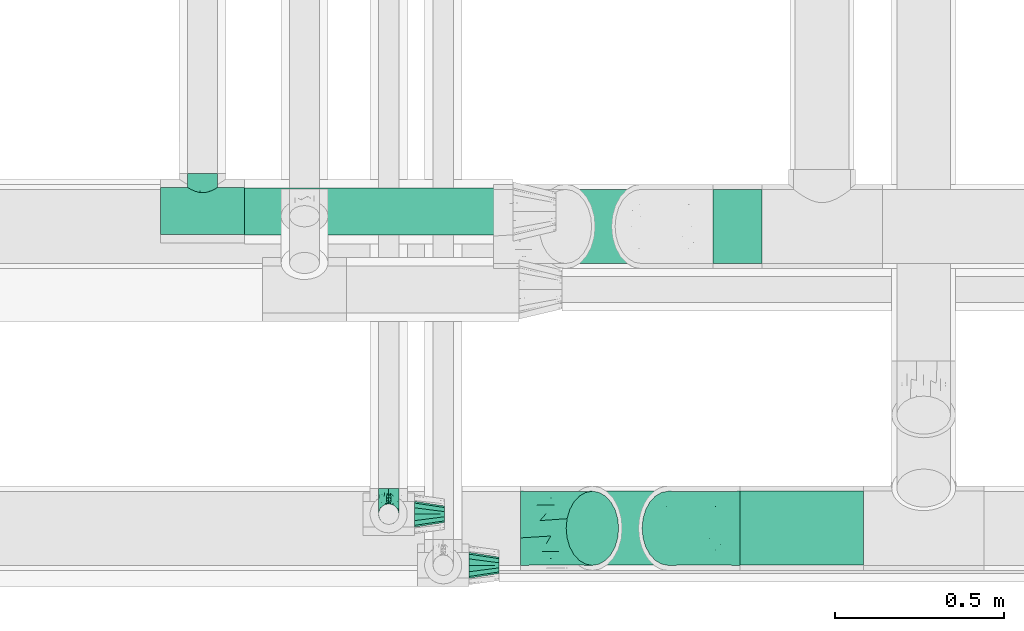
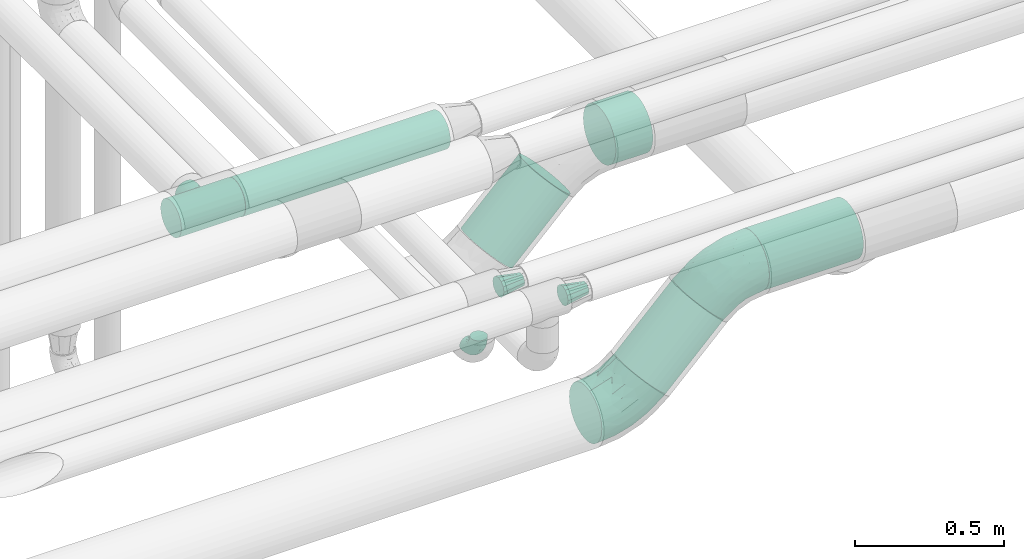
# One storey, part 603 of 824: 6 flow fittings, 5 flow segments.
"""IFC2X3 building model written with IfcOpenShell, lengths in millimetres."""

from ifc_helpers import new_model, entity, si_unit, converted_unit, derived_unit, direction, frame, origin, origin_2d_with_axis, place, context, subcontext, project, spatial, circle, extrude, faceted_brep, source, transform, mapped, material, type_object, type_shapes, element, save


model = new_model("IFC2X3")

# Units and contexts
model_context = context("Model", 3, precision=0.01, world=origin(), true_north=direction((6.12303176911189e-17, 1.0)))
body_context = subcontext(model_context, "Body", "Model", "MODEL_VIEW")
ifc_project = project(units=[si_unit("LENGTHUNIT", "METRE", prefix="MILLI"), si_unit("AREAUNIT", "SQUARE_METRE"), si_unit("VOLUMEUNIT", "CUBIC_METRE"), converted_unit("PLANEANGLEUNIT", "DEGREE", entity("IfcRatioMeasure", 0.0174532925199433), si_unit("PLANEANGLEUNIT", "RADIAN"), dimensions=[0, 0, 0, 0, 0, 0, 0]), si_unit("MASSUNIT", "GRAM", prefix="KILO"), derived_unit("MASSDENSITYUNIT", [(si_unit("MASSUNIT", "GRAM", prefix="KILO"), 1), (si_unit("LENGTHUNIT", "METRE"), -3)]), derived_unit("MOMENTOFINERTIAUNIT", [(si_unit("LENGTHUNIT", "METRE"), 4)]), si_unit("TIMEUNIT", "SECOND"), si_unit("FREQUENCYUNIT", "HERTZ"), si_unit("THERMODYNAMICTEMPERATUREUNIT", "DEGREE_CELSIUS"), derived_unit("THERMALTRANSMITTANCEUNIT", [(si_unit("MASSUNIT", "GRAM", prefix="KILO"), 1), (si_unit("THERMODYNAMICTEMPERATUREUNIT", "KELVIN"), -1), (si_unit("TIMEUNIT", "SECOND"), -3)]), derived_unit("VOLUMETRICFLOWRATEUNIT", [(si_unit("LENGTHUNIT", "METRE"), 3), (si_unit("TIMEUNIT", "SECOND"), -1)]), derived_unit("MASSFLOWRATEUNIT", [(si_unit("MASSUNIT", "GRAM", prefix="KILO"), 1), (si_unit("TIMEUNIT", "SECOND"), -1)]), derived_unit("ROTATIONALFREQUENCYUNIT", [(si_unit("TIMEUNIT", "SECOND"), -1)]), si_unit("ELECTRICCURRENTUNIT", "AMPERE"), si_unit("ELECTRICVOLTAGEUNIT", "VOLT"), si_unit("POWERUNIT", "WATT"), si_unit("FORCEUNIT", "NEWTON", prefix="KILO"), si_unit("ILLUMINANCEUNIT", "LUX"), si_unit("LUMINOUSFLUXUNIT", "LUMEN"), si_unit("LUMINOUSINTENSITYUNIT", "CANDELA"), derived_unit("USERDEFINED", [(si_unit("MASSUNIT", "GRAM", prefix="KILO"), -1), (si_unit("LENGTHUNIT", "METRE"), -2), (si_unit("TIMEUNIT", "SECOND"), 3), (si_unit("LUMINOUSFLUXUNIT", "LUMEN"), 1)]), derived_unit("LINEARVELOCITYUNIT", [(si_unit("LENGTHUNIT", "METRE"), 1), (si_unit("TIMEUNIT", "SECOND"), -1)]), si_unit("PRESSUREUNIT", "PASCAL"), derived_unit("USERDEFINED", [(si_unit("LENGTHUNIT", "METRE"), -2), (si_unit("MASSUNIT", "GRAM", prefix="KILO"), 1), (si_unit("TIMEUNIT", "SECOND"), -2)]), derived_unit("LINEARFORCEUNIT", [(si_unit("MASSUNIT", "GRAM", prefix="KILO"), 1), (si_unit("LENGTHUNIT", "METRE"), 1), (si_unit("TIMEUNIT", "SECOND"), -2), (si_unit("LENGTHUNIT", "METRE"), -1)]), derived_unit("PLANARFORCEUNIT", [(si_unit("MASSUNIT", "GRAM", prefix="KILO"), 1), (si_unit("LENGTHUNIT", "METRE"), 1), (si_unit("TIMEUNIT", "SECOND"), -2), (si_unit("LENGTHUNIT", "METRE"), -2)])], contexts=[model_context])

# Site, building, storey
site_placement = place(None, origin())
site = spatial("IfcSite", under=ifc_project, at=site_placement, CompositionType="ELEMENT")
building_placement = place(site_placement, origin())
building = spatial("IfcBuilding", under=site, at=building_placement, CompositionType="ELEMENT")
storey_placement = place(building_placement, frame((0.0, 0.0, 28200.0)))
storey = spatial("IfcBuildingStorey", under=building, at=storey_placement, CompositionType="ELEMENT", Elevation=28200.0)

# Flow segments
pipe_segment_type_1 = type_object("IfcPipeSegmentType", PredefinedType="NOTDEFINED")
flow_segment_1_placement = place(storey_placement, frame((37506.49, 6263.9, 2788.9)))
element("IfcFlowSegment", 1, at=flow_segment_1_placement, inside=storey, type_object=pipe_segment_type_1, context=body_context, shape_type="SweptSolid", body=[
    extrude(circle(Radius=109.5, at=origin_2d_with_axis()), frame((0.0, 111.1, 111.1), z_axis=(1.0, 0.0, 0.0), x_axis=(0.0, 1.0, 0.0)), (0.0, 0.0, 1.0), 363.810001287764),
])
flow_segment_2_placement = place(storey_placement, frame((36991.07, 6263.9, 2508.84)))
element("IfcFlowSegment", 2, at=flow_segment_2_placement, inside=storey, type_object=pipe_segment_type_1, context=body_context, shape_type="SweptSolid", body=[
    extrude(circle(Radius=109.5, at=origin_2d_with_axis()), frame((79.02, 111.1, 79.02), z_axis=(0.70710679250001, 0.0, 0.707106769873085), x_axis=(0.0, 1.0, 0.0)), (0.0, 0.0, 1.0), 317.157302199655),
])
flow_segment_3_placement = place(storey_placement, frame((37426.66, 7155.11, 2788.78)))
element("IfcFlowSegment", 3, at=flow_segment_3_placement, inside=storey, type_object=pipe_segment_type_1, context=body_context, shape_type="SweptSolid", body=[
    extrude(circle(Radius=109.5, at=origin_2d_with_axis()), frame((0.0, 111.1, 111.1), z_axis=(1.0, 0.0, 0.0), x_axis=(0.0, 1.0, 0.0)), (0.0, 0.0, 1.0), 143.641200592173),
])
flow_segment_4_placement = place(storey_placement, frame((36911.29, 7155.11, 2508.8)))
element("IfcFlowSegment", 4, at=flow_segment_4_placement, inside=storey, type_object=pipe_segment_type_1, context=body_context, shape_type="SweptSolid", body=[
    extrude(circle(Radius=109.5, at=origin_2d_with_axis()), frame((79.02, 111.1, 79.03), z_axis=(0.707128324867819, 0.0, 0.707085236848877), x_axis=(0.0, 1.0, 0.0)), (0.0, 0.0, 1.0), 317.064992744885),
])
pipe_segment_type_2 = type_object("IfcPipeSegmentType", PredefinedType="NOTDEFINED")
flow_segment_5_placement = place(storey_placement, frame((36043.07, 7238.4, 3028.4)))
element("IfcFlowSegment", 5, at=flow_segment_5_placement, inside=storey, type_object=pipe_segment_type_2, context=body_context, shape_type="SweptSolid", body=[
    extrude(circle(Radius=70.0, at=origin_2d_with_axis()), frame((0.0, 71.6, 71.6), z_axis=(1.0, 0.0, 0.0), x_axis=(0.0, 1.0, 0.0)), (0.0, 0.0, 1.0), 791.966250687601),
])

# Flow fittings
ifc_material = material()
pipe_fitting_type_1 = type_object("IfcPipeFittingType", PredefinedType="NOTDEFINED", material=ifc_material)
shared_shape_1 = source(origin(), body_context, "Body", "Brep", [
    faceted_brep([(-76.0, 15.07, -26.11), (-76.0, 7.8, -29.12), (-76.0, 0.0, -30.15), (-76.0, -7.8, -29.12), (-76.0, -15.08, -26.11), (-76.0, -21.32, -21.32), (-76.0, -26.11, -15.08), (-76.0, -29.12, -7.8), (-76.0, -30.15, 0.0), (-76.0, -29.12, 7.8), (-76.0, -26.11, 15.07), (-76.0, -21.32, 21.32), (-76.0, -15.08, 26.11), (-76.0, -7.8, 29.12), (-76.0, 0.0, 30.15), (-76.0, 7.8, 29.12), (-76.0, 15.07, 26.11), (-76.0, 21.32, 21.32), (-76.0, 26.11, 15.07), (-76.0, 29.12, 7.8), (-76.0, 30.15, 0.0), (-76.0, 29.12, -7.8), (-76.0, 26.11, -15.08), (-76.0, 21.32, -21.32), (0.0, 76.0, -30.15), (-7.8, 76.0, -29.12), (-15.07, 76.0, -26.11), (-21.32, 76.0, -21.32), (-26.11, 76.0, -15.08), (-29.12, 76.0, -7.8), (-30.15, 76.0, 0.0), (-29.12, 76.0, 7.8), (-26.11, 76.0, 15.07), (-21.32, 76.0, 21.32), (-15.07, 76.0, 26.11), (-7.8, 76.0, 29.12), (0.0, 76.0, 30.15), (7.8, 76.0, 29.12), (15.08, 76.0, 26.11), (21.32, 76.0, 21.32), (26.11, 76.0, 15.07), (29.12, 76.0, 7.8), (30.15, 76.0, 0.0), (29.12, 76.0, -7.8), (26.11, 76.0, -15.08), (21.32, 76.0, -21.32), (15.08, 76.0, -26.11), (7.8, 76.0, -29.12), (10.79, 31.43, 21.07), (4.32, 31.7, 25.72), (1.65, 15.19, 19.92), (-61.17, -27.8, 0.0), (-51.1, -25.49, 9.84), (-56.14, -10.61, 27.27), (-31.7, -4.32, 25.72), (-39.75, 1.72, 29.41), (-43.2, -24.95, 0.0), (-1.86, 1.86, 0.0), (4.49, 7.65, 5.78), (-7.82, -4.61, 5.83), (-56.21, -22.79, 17.21), (-58.98, -3.38, 29.7), (-53.96, 5.6, 30.07), (-10.86, 10.86, 25.48), (-17.2, -2.6, 20.44), (-49.15, -16.01, 22.7), (-22.18, -14.24, 7.99), (-28.4, -17.42, 0.0), (-13.61, -9.88, 0.0), (-39.0, 23.48, 27.76), (-58.76, 12.54, 28.36), (-41.61, 15.41, 29.48), (16.01, 49.15, 22.7), (-58.55, 25.93, 19.53), (-51.53, 33.5, 13.51), (-64.92, 28.76, 12.4), (-7.48, 23.14, 28.25), (-1.72, 39.75, 29.41), (-12.04, 27.88, 29.88), (-63.91, 18.81, 24.52), (-11.63, 65.16, 28.18), (-4.97, 57.02, 30.05), (9.88, 13.61, 0.0), (-62.5, 31.74, 5.02), (-45.17, 30.98, 21.2), (-21.78, 9.76, 28.58), (10.61, 56.14, 27.27), (-32.09, 54.42, 13.26), (22.79, 56.21, 17.21), (15.38, 31.17, 15.63), (25.49, 51.1, 9.84), (21.84, 36.35, 5.92), (24.95, 43.2, 0.0), (3.38, 58.98, 29.7), (-31.17, -15.38, 15.63), (-39.39, 41.78, 15.45), (-34.56, 41.13, 20.79), (-39.81, -23.25, 5.49), (27.8, 61.17, 0.0), (-31.74, 62.5, 5.02), (-53.07, 36.29, 0.0), (-42.95, 42.95, 7.29), (-36.29, 53.07, 0.0), (-19.83, 58.51, 24.79), (-25.48, 60.2, 19.41), (-14.53, 50.96, 28.57), (-13.31, 37.09, 30.07), (-26.16, 40.06, 26.4), (-32.43, -10.35, 21.9), (17.42, 28.4, 0.0), (14.24, 22.18, 7.99), (-38.67, 9.72, 30.15), (-24.66, 17.36, 30.09), (-37.08, 31.49, 24.99), (-49.27, 22.83, 25.24), (-20.8, 38.81, 28.63), (-27.58, 27.58, 29.2), (-36.07, -20.23, 10.71), (-15.19, -6.16, 14.9), (6.6, 15.4, 14.49), (-2.51, 2.51, 11.35), (-65.16, 11.63, -28.18), (-49.15, -16.01, -22.7), (-57.02, 4.97, -30.05), (-25.93, 58.55, -19.53), (-33.5, 51.53, -13.51), (-28.76, 64.92, -12.4), (-60.2, 25.48, -19.41), (-58.51, 19.83, -24.79), (4.61, 7.82, -5.83), (-7.65, -4.49, -5.78), (-2.51, 2.51, -11.35), (-62.5, 31.74, -5.02), (-50.96, 14.53, -28.57), (-37.09, 13.31, -30.07), (-42.95, 42.95, -7.29), (25.49, 51.1, -9.84), (22.79, 56.21, -17.21), (-40.06, 26.16, -26.4), (3.38, 58.98, -29.7), (-5.6, 53.96, -30.07), (-27.88, 12.04, -29.88), (-9.76, 21.78, -28.58), (-23.14, 7.48, -28.25), (-51.1, -25.49, -9.84), (15.38, 31.17, -15.63), (16.01, 49.15, -22.7), (-23.48, 39.0, -27.76), (-12.54, 58.76, -28.36), (-15.41, 41.61, -29.48), (-56.21, -22.79, -17.21), (-9.72, 38.67, -30.15), (-17.36, 24.66, -30.09), (-22.18, -14.24, -7.99), (-41.13, 34.56, -20.79), (-31.74, 62.5, -5.02), (-58.98, -3.38, -29.7), (-31.17, -15.38, -15.63), (-56.14, -10.61, -27.27), (14.24, 22.18, -7.99), (23.25, 39.81, -5.49), (-31.49, 37.08, -24.99), (-15.19, -6.16, -14.9), (1.65, 15.19, -19.92), (-18.81, 63.91, -24.52), (-32.59, -11.62, -20.84), (-31.7, -4.32, -25.72), (-17.2, -2.6, -20.44), (-39.75, 1.72, -29.41), (-54.42, 32.09, -13.26), (-30.98, 45.17, -21.2), (10.61, 56.14, -27.27), (10.23, 31.31, -21.52), (4.32, 31.7, -25.72), (-41.78, 39.39, -15.45), (-1.72, 39.75, -29.41), (-36.35, -21.84, -5.92), (-22.83, 49.27, -25.24), (-38.81, 20.8, -28.63), (-27.58, 27.58, -29.2), (-10.86, 10.86, -25.48), (20.23, 36.07, -10.71), (6.6, 15.4, -14.49)], [[[0, 1, 2, 3, 4, 5, 6, 7, 8, 9, 10, 11, 12, 13, 14, 15, 16, 17, 18, 19, 20, 21, 22, 23]], [[24, 25, 26, 27, 28, 29, 30, 31, 32, 33, 34, 35, 36, 37, 38, 39, 40, 41, 42, 43, 44, 45, 46, 47]], [[48, 49, 50]], [[51, 52, 9]], [[53, 54, 55]], [[9, 52, 10]], [[56, 52, 51]], [[57, 58, 59]], [[11, 10, 60]], [[14, 61, 62]], [[63, 54, 64]], [[65, 12, 11]], [[65, 53, 12]], [[66, 67, 68]], [[69, 70, 71]], [[72, 39, 38]], [[73, 74, 75]], [[15, 70, 16]], [[76, 77, 78]], [[16, 79, 17]], [[13, 61, 14]], [[35, 80, 81]], [[14, 62, 15]], [[17, 73, 18]], [[57, 82, 58]], [[20, 19, 83]], [[75, 19, 18]], [[70, 15, 62]], [[73, 84, 74]], [[78, 85, 76]], [[38, 86, 72]], [[32, 31, 87]], [[88, 89, 90]], [[91, 92, 90]], [[72, 86, 49]], [[36, 93, 37]], [[75, 83, 19]], [[36, 35, 81]], [[60, 94, 65]], [[40, 90, 41]], [[95, 96, 87]], [[88, 90, 40]], [[66, 97, 67]], [[90, 98, 41]], [[40, 39, 88]], [[99, 31, 30]], [[20, 83, 100]], [[101, 102, 100]], [[52, 60, 10]], [[102, 99, 30]], [[96, 103, 104]], [[83, 101, 100]], [[12, 53, 13]], [[104, 103, 33]], [[105, 106, 81]], [[107, 105, 103]], [[64, 54, 108]], [[80, 103, 105]], [[80, 35, 34]], [[34, 33, 103]], [[86, 38, 37]], [[109, 110, 82]], [[71, 111, 112]], [[69, 107, 113]], [[79, 73, 17]], [[114, 113, 84]], [[33, 32, 104]], [[115, 107, 116]], [[105, 115, 106]], [[93, 81, 77]], [[54, 53, 65]], [[61, 53, 55]], [[108, 94, 64]], [[54, 63, 85]], [[93, 86, 37]], [[77, 76, 49]], [[77, 49, 86]], [[49, 63, 50]], [[60, 52, 117]], [[65, 11, 60]], [[39, 72, 88]], [[89, 88, 72]], [[71, 70, 62]], [[79, 70, 114]], [[103, 96, 107]], [[69, 113, 114]], [[112, 106, 116]], [[77, 81, 106]], [[112, 116, 71]], [[112, 55, 85]], [[64, 50, 63]], [[57, 59, 68]], [[32, 87, 104]], [[96, 104, 87]], [[94, 118, 64]], [[50, 119, 89]], [[50, 64, 118]], [[50, 89, 48]], [[81, 93, 36]], [[86, 93, 77]], [[53, 61, 13]], [[62, 61, 55]], [[71, 62, 111]], [[69, 71, 116]], [[95, 101, 74]], [[99, 101, 87]], [[118, 66, 59]], [[117, 97, 66]], [[117, 66, 94]], [[91, 89, 110]], [[91, 110, 109]], [[110, 89, 119]], [[9, 8, 51]], [[98, 90, 92]], [[98, 42, 41]], [[101, 83, 74]], [[101, 99, 102]], [[87, 31, 99]], [[62, 55, 111]], [[55, 112, 111]], [[107, 69, 116]], [[70, 69, 114]], [[107, 96, 113]], [[84, 113, 96]], [[84, 96, 95]], [[114, 84, 73]], [[70, 79, 16]], [[73, 79, 114]], [[54, 85, 55]], [[76, 85, 63]], [[49, 76, 63]], [[77, 106, 78]], [[106, 112, 78]], [[85, 78, 112]], [[73, 75, 18]], [[83, 75, 74]], [[103, 80, 34]], [[81, 80, 105]], [[101, 95, 87]], [[84, 95, 74]], [[106, 115, 116]], [[105, 107, 115]], [[120, 59, 58]], [[82, 110, 58]], [[119, 58, 110]], [[118, 59, 120]], [[66, 68, 59]], [[54, 65, 108]], [[94, 108, 65]], [[66, 118, 94]], [[50, 118, 120]], [[50, 120, 119]], [[119, 120, 58]], [[89, 72, 48]], [[49, 48, 72]], [[60, 117, 94]], [[117, 52, 97]], [[52, 56, 97]], [[67, 97, 56]], [[92, 91, 109]], [[89, 91, 90]], [[121, 1, 0]], [[122, 5, 4]], [[2, 1, 123]], [[124, 125, 126]], [[127, 128, 23]], [[129, 130, 131]], [[100, 132, 20]], [[133, 134, 123]], [[135, 100, 102]], [[136, 137, 44]], [[133, 128, 138]], [[24, 139, 140]], [[141, 142, 143]], [[121, 128, 133]], [[6, 144, 7]], [[137, 145, 146]], [[144, 51, 7]], [[147, 148, 149]], [[144, 6, 150]], [[149, 151, 152]], [[153, 68, 67]], [[154, 128, 127]], [[30, 155, 102]], [[43, 42, 98]], [[156, 3, 2]], [[157, 144, 150]], [[158, 4, 3]], [[24, 140, 25]], [[155, 135, 102]], [[159, 160, 109]], [[30, 29, 155]], [[147, 138, 161]], [[27, 124, 28]], [[57, 129, 82]], [[162, 163, 131]], [[27, 26, 164]], [[148, 26, 25]], [[165, 166, 167]], [[24, 47, 139]], [[143, 168, 141]], [[22, 21, 169]], [[125, 124, 170]], [[148, 25, 140]], [[46, 146, 171]], [[158, 122, 4]], [[0, 23, 128]], [[1, 121, 123]], [[109, 82, 159]], [[45, 44, 137]], [[146, 46, 45]], [[136, 43, 98]], [[132, 21, 20]], [[136, 98, 92]], [[172, 173, 146]], [[46, 171, 47]], [[43, 136, 44]], [[174, 154, 169]], [[171, 173, 175]], [[6, 5, 150]], [[126, 29, 28]], [[176, 56, 144]], [[122, 158, 166]], [[164, 124, 27]], [[177, 161, 170]], [[23, 22, 127]], [[178, 138, 179]], [[133, 178, 134]], [[156, 123, 168]], [[156, 158, 3]], [[168, 143, 166]], [[168, 166, 158]], [[166, 180, 167]], [[173, 171, 146]], [[139, 171, 175]], [[172, 145, 163]], [[173, 180, 142]], [[5, 122, 150]], [[157, 150, 122]], [[137, 136, 181]], [[146, 45, 137]], [[149, 148, 140]], [[164, 148, 177]], [[128, 154, 138]], [[147, 161, 177]], [[152, 134, 179]], [[168, 123, 134]], [[152, 179, 149]], [[152, 175, 142]], [[57, 130, 129]], [[157, 165, 167]], [[22, 169, 127]], [[154, 127, 169]], [[163, 167, 180]], [[162, 157, 167]], [[173, 163, 180]], [[182, 163, 145]], [[123, 156, 2]], [[158, 156, 168]], [[171, 139, 47]], [[140, 139, 175]], [[149, 140, 151]], [[147, 149, 179]], [[174, 135, 125]], [[132, 135, 169]], [[176, 157, 153]], [[176, 153, 67]], [[153, 157, 162]], [[182, 159, 129]], [[181, 160, 159]], [[181, 159, 145]], [[51, 144, 56]], [[51, 8, 7]], [[135, 132, 100]], [[169, 21, 132]], [[126, 155, 29]], [[135, 155, 125]], [[140, 175, 151]], [[175, 152, 151]], [[138, 147, 179]], [[148, 147, 177]], [[138, 154, 161]], [[170, 161, 154]], [[170, 154, 174]], [[177, 170, 124]], [[148, 164, 26]], [[124, 164, 177]], [[173, 142, 175]], [[143, 142, 180]], [[166, 143, 180]], [[168, 134, 141]], [[134, 152, 141]], [[142, 141, 152]], [[124, 126, 28]], [[155, 126, 125]], [[128, 121, 0]], [[123, 121, 133]], [[135, 174, 169]], [[170, 174, 125]], [[134, 178, 179]], [[133, 138, 178]], [[130, 153, 162]], [[68, 153, 130]], [[57, 68, 130]], [[182, 129, 131]], [[159, 82, 129]], [[157, 122, 165]], [[166, 165, 122]], [[163, 162, 167]], [[162, 131, 130]], [[145, 172, 146]], [[163, 173, 172]], [[159, 182, 145]], [[131, 163, 182]], [[56, 176, 67]], [[157, 176, 144]], [[137, 181, 145]], [[181, 136, 160]], [[136, 92, 160]], [[109, 160, 92]]]),
])
type_shapes(pipe_fitting_type_1, [shared_shape_1])
flow_fitting_1_placement = place(storey_placement, frame((36468.72, 6416.57, 2850.0), z_axis=(-1.0, 0.0, 0.0), x_axis=(0.0, -1.0, 0.0)))
element("IfcFlowFitting", 6, at=flow_fitting_1_placement, inside=storey, type_object=pipe_fitting_type_1, material=ifc_material, context=body_context, shape_type="MappedRepresentation", body=[
    mapped(shared_shape_1, transform((0.0, 0.0, 0.0), scale=1.0)),
])
pipe_fitting_type_2 = type_object("IfcPipeFittingType", PredefinedType="NOTDEFINED", material=ifc_material)
shared_shape_2 = source(origin(), body_context, "Body", "Brep", [
    faceted_brep([(-124.0, 18.08, -67.47), (-124.0, 0.0, -69.85), (-124.0, -18.08, -67.47), (-124.0, -34.93, -60.49), (-124.0, -49.39, -49.39), (-124.0, -60.49, -34.93), (-124.0, -63.98, -26.5), (-124.0, -67.47, -18.08), (-124.0, -69.85, 0.0), (-124.0, -67.47, 18.08), (-124.0, -63.98, 26.5), (-124.0, -60.49, 34.92), (-124.0, -49.39, 49.39), (-124.0, -34.93, 60.49), (-124.0, -18.08, 67.47), (-124.0, 0.0, 69.85), (-124.0, 18.08, 67.47), (-124.0, 34.92, 60.49), (-124.0, 49.39, 49.39), (-124.0, 60.49, 34.92), (-124.0, 67.47, 18.08), (-124.0, 69.85, 0.0), (-124.0, 67.47, -18.08), (-124.0, 60.49, -34.93), (-124.0, 49.39, -49.39), (-124.0, 34.92, -60.49), (124.0, 49.39, -49.39), (124.0, 60.49, -34.93), (124.0, 67.47, -18.08), (124.0, 69.85, 0.0), (124.0, 67.47, 18.08), (124.0, 60.49, 34.92), (124.0, 49.39, 49.39), (124.0, 34.92, 60.49), (124.0, 18.08, 67.47), (124.0, 0.0, 69.85), (124.0, -18.08, 67.47), (124.0, -34.93, 60.49), (124.0, -49.39, 49.39), (124.0, -60.49, 34.92), (124.0, -63.98, 26.5), (124.0, -67.47, 18.08), (124.0, -69.85, 0.0), (124.0, -67.47, -18.08), (124.0, -63.98, -26.5), (124.0, -60.49, -34.93), (124.0, -49.39, -49.39), (124.0, -34.93, -60.49), (124.0, -18.08, -67.47), (124.0, 0.0, -69.85), (124.0, 18.08, -67.47), (124.0, 34.92, -60.49), (41.64, -68.1, 15.55), (43.05, -68.97, 7.77), (44.45, -69.85, 0.0), (33.91, -63.66, 28.74), (22.41, -58.36, 38.39), (7.93, -54.46, 43.74), (15.17, -56.41, 41.06), (-33.91, -63.66, 28.74), (-44.45, -69.85, 0.0), (-43.05, -68.97, 7.77), (-41.64, -68.1, 15.55), (-22.41, -58.36, 38.39), (-7.93, -54.46, 43.74), (0.0, -54.46, 43.74), (22.41, -58.36, -38.39), (-33.91, -63.66, -28.74), (15.17, -56.41, -41.06), (7.93, -54.46, -43.74), (33.91, -63.66, -28.74), (41.64, -68.1, -15.55), (43.05, -68.97, -7.77), (-7.93, -54.46, -43.74), (-22.41, -58.36, -38.39), (0.0, -54.46, -43.74), (-41.64, -68.1, -15.55), (-43.05, -68.97, -7.77), (31.43, -111.0, -31.43), (38.49, -111.0, -22.23), (42.94, -111.0, -11.5), (44.45, -111.0, 0.0), (42.94, -111.0, 11.5), (38.49, -111.0, 22.22), (31.43, -111.0, 31.43), (22.23, -111.0, 38.49), (11.5, -111.0, 42.94), (0.0, -111.0, 44.45), (-11.5, -111.0, 42.94), (-22.22, -111.0, 38.49), (-31.43, -111.0, 31.43), (-38.49, -111.0, 22.22), (-42.94, -111.0, 11.5), (-44.45, -111.0, 0.0), (-42.94, -111.0, -11.5), (-38.49, -111.0, -22.23), (-31.43, -111.0, -31.43), (-22.22, -111.0, -38.49), (-11.5, -111.0, -42.94), (0.0, -111.0, -44.45), (11.5, -111.0, -42.94), (22.23, -111.0, -38.49)], [[[0, 1, 2, 3, 4, 5, 6, 7, 8, 9, 10, 11, 12, 13, 14, 15, 16, 17, 18, 19, 20, 21, 22, 23, 24, 25]], [[26, 27, 28, 29, 30, 31, 32, 33, 34, 35, 36, 37, 38, 39, 40, 41, 42, 43, 44, 45, 46, 47, 48, 49, 50, 51]], [[42, 41, 52]], [[42, 52, 53, 54]], [[41, 55, 52]], [[39, 38, 56]], [[56, 55, 39]], [[38, 57, 58, 56]], [[38, 12, 57]], [[39, 55, 41, 40]], [[59, 11, 10, 9]], [[8, 60, 61, 62]], [[9, 8, 62]], [[62, 59, 9]], [[63, 64, 12]], [[63, 11, 59]], [[11, 63, 12]], [[12, 64, 65, 57]], [[38, 37, 13, 12]], [[15, 14, 36, 35]], [[14, 13, 37, 36]], [[16, 15, 35, 34]], [[31, 30, 20, 19]], [[18, 17, 33, 32]], [[19, 18, 32, 31]], [[34, 33, 17, 16]], [[21, 20, 30, 29]], [[22, 28, 27, 23]], [[27, 26, 24, 23]], [[29, 28, 22, 21]], [[49, 48, 2, 1]], [[0, 25, 51, 50]], [[1, 0, 50, 49]], [[26, 51, 25, 24]], [[47, 3, 2, 48]], [[47, 46, 4, 3]], [[46, 45, 66]], [[67, 7, 6, 5]], [[46, 66, 68, 69]], [[45, 70, 66]], [[46, 69, 4]], [[43, 42, 71]], [[71, 70, 43]], [[42, 54, 72, 71]], [[43, 70, 45, 44]], [[73, 74, 4]], [[5, 4, 74]], [[74, 67, 5]], [[4, 69, 75, 73]], [[67, 76, 7]], [[76, 8, 7]], [[8, 76, 77, 60]], [[78, 79, 80, 81, 82, 83, 84, 85, 86, 87, 88, 89, 90, 91, 92, 93, 94, 95, 96, 97, 98, 99, 100, 101]], [[87, 64, 88]], [[63, 90, 89]], [[90, 59, 91]], [[63, 89, 88]], [[61, 60, 93]], [[93, 92, 61]], [[92, 91, 62]], [[92, 62, 61]], [[59, 62, 91]], [[90, 63, 59]], [[53, 81, 54]], [[88, 64, 63]], [[87, 57, 65, 64]], [[85, 56, 58]], [[84, 56, 85]], [[52, 83, 82]], [[84, 83, 55]], [[57, 87, 86]], [[58, 57, 86]], [[85, 58, 86]], [[56, 84, 55]], [[55, 83, 52]], [[53, 52, 82]], [[81, 53, 82]], [[80, 72, 81]], [[68, 101, 100]], [[68, 66, 101]], [[80, 71, 72]], [[80, 79, 71]], [[77, 76, 94]], [[78, 70, 79]], [[72, 54, 81]], [[71, 79, 70]], [[99, 69, 100]], [[66, 70, 78]], [[100, 69, 68]], [[66, 78, 101]], [[99, 73, 75, 69]], [[74, 98, 97]], [[96, 74, 97]], [[76, 95, 94]], [[96, 95, 67]], [[73, 99, 98]], [[98, 74, 73]], [[74, 96, 67]], [[67, 95, 76]], [[93, 77, 94]], [[77, 93, 60]]]),
])
type_shapes(pipe_fitting_type_2, [shared_shape_2])
flow_fitting_2_placement = place(storey_placement, frame((35919.07, 7311.73, 3100.0), z_axis=(0.0, 0.0, -1.0), x_axis=(1.0, 0.0, 0.0)))
element("IfcFlowFitting", 7, at=flow_fitting_2_placement, inside=storey, type_object=pipe_fitting_type_2, material=ifc_material, context=body_context, shape_type="MappedRepresentation", body=[
    mapped(shared_shape_2, transform((0.0, 0.0, 0.0), scale=1.0)),
])
pipe_fitting_type_3 = type_object("IfcPipeFittingType", PredefinedType="NOTDEFINED", material=ifc_material)
shared_shape_3 = source(origin(), body_context, "Body", "Brep", [
    faceted_brep([(-124.26, 54.75, -94.83), (-124.26, 28.34, -105.77), (-124.26, 0.0, -109.5), (-124.26, -28.34, -105.77), (-124.26, -54.75, -94.83), (-124.26, -77.43, -77.43), (-124.26, -94.83, -54.75), (-124.26, -105.77, -28.34), (-124.26, -109.5, 0.0), (-124.26, -105.77, 28.34), (-124.26, -94.83, 54.75), (-124.26, -77.43, 77.43), (-124.26, -54.75, 94.83), (-124.26, -28.34, 105.77), (-124.26, 0.0, 109.5), (-124.26, 28.34, 105.77), (-124.26, 54.75, 94.83), (-124.26, 77.43, 77.43), (-124.26, 94.83, 54.75), (-124.26, 105.77, 28.34), (-124.26, 109.5, 0.0), (-124.26, 105.77, -28.34), (-124.26, 94.83, -54.75), (-124.26, 77.43, -77.43), (87.87, 87.87, -109.5), (67.83, 107.91, -105.77), (49.15, 126.58, -94.83), (33.12, 142.62, -77.43), (20.81, 154.92, -54.75), (13.08, 162.66, -28.34), (10.44, 165.3, 0.0), (13.08, 162.66, 28.34), (20.81, 154.92, 54.75), (33.12, 142.62, 77.43), (49.15, 126.58, 94.83), (67.83, 107.91, 105.77), (87.87, 87.87, 109.5), (107.91, 67.83, 105.77), (126.58, 49.15, 94.83), (142.62, 33.12, 77.43), (154.92, 20.81, 54.75), (162.66, 13.08, 28.34), (165.3, 10.44, 0.0), (162.66, 13.08, -28.34), (154.92, 20.81, -54.75), (142.62, 33.12, -77.43), (126.58, 49.15, -94.83), (107.91, 67.83, -105.77), (71.66, 17.62, 100.41), (2.28, -89.46, 0.0), (-32.68, -94.9, 29.76), (-60.2, -104.46, 0.0), (40.7, 64.7, 108.77), (-50.51, -81.19, 64.81), (-37.02, -58.34, 85.18), (-45.56, -6.91, 108.2), (14.88, -35.92, 89.14), (-63.13, -38.21, 100.41), (-13.48, 32.55, 108.99), (10.95, 77.81, 101.97), (-55.11, 49.0, 102.07), (-33.95, 81.95, 88.86), (-74.53, 16.96, 108.77), (31.61, -76.31, 21.78), (90.21, -44.0, 29.76), (-61.62, 94.79, 68.49), (-47.74, 115.26, 44.52), (27.74, -66.97, 50.42), (-65.18, -94.31, 47.39), (-34.75, 129.14, 22.76), (-87.1, 113.16, 0.0), (61.65, -64.87, 0.0), (116.43, -31.29, 0.0), (67.43, -15.08, 85.18), (80.19, -41.7, 48.45), (93.12, -21.69, 64.81), (37.11, 27.33, 108.2), (15.28, -56.47, 71.64), (-8.95, 119.52, 68.0), (-18.43, 141.61, 0.0), (-51.36, 124.0, 0.0), (8.08, -19.5, 99.45), (-74.53, 16.96, -108.77), (-45.56, -6.91, -108.2), (90.21, -44.0, -29.76), (-33.95, 81.95, -88.86), (4.32, 73.61, -102.07), (-66.74, 115.88, -22.76), (71.66, 17.62, -100.41), (37.11, 27.33, -108.2), (-47.74, 115.26, -44.52), (-50.51, -81.19, -64.81), (-37.02, -58.34, -85.18), (-78.18, 90.84, -68.0), (-62.76, 47.28, -101.97), (-27.22, -86.19, -48.45), (-63.13, -38.21, -100.41), (-32.68, -94.9, -29.76), (-13.48, 32.55, -108.99), (8.08, -19.5, -99.45), (14.88, -35.92, -89.14), (27.74, -66.97, -50.42), (31.61, -76.31, -21.78), (29.12, -50.74, -71.64), (93.12, -21.69, -64.81), (112.78, -20.6, -47.39), (-23.45, 110.6, -68.49), (67.43, -15.08, -85.18), (40.7, 64.7, -108.77)], [[[0, 1, 2, 3, 4, 5, 6, 7, 8, 9, 10, 11, 12, 13, 14, 15, 16, 17, 18, 19, 20, 21, 22, 23]], [[24, 25, 26, 27, 28, 29, 30, 31, 32, 33, 34, 35, 36, 37, 38, 39, 40, 41, 42, 43, 44, 45, 46, 47]], [[38, 37, 48]], [[49, 50, 51]], [[36, 35, 52]], [[11, 53, 54]], [[51, 9, 8]], [[14, 13, 55]], [[56, 57, 54]], [[58, 59, 60]], [[34, 33, 61]], [[13, 12, 57]], [[55, 58, 62]], [[49, 63, 50]], [[54, 57, 12]], [[16, 15, 60]], [[40, 64, 41]], [[61, 16, 60]], [[9, 51, 50]], [[18, 65, 66]], [[15, 14, 62]], [[67, 53, 68]], [[32, 31, 66]], [[19, 69, 70]], [[12, 11, 54]], [[70, 20, 19]], [[19, 18, 66]], [[53, 11, 10]], [[61, 17, 16]], [[18, 17, 65]], [[64, 63, 71]], [[72, 41, 64]], [[38, 73, 39]], [[74, 75, 67]], [[58, 52, 59]], [[52, 76, 36]], [[63, 67, 50]], [[76, 37, 36]], [[77, 53, 67]], [[40, 75, 74]], [[78, 61, 33]], [[38, 48, 73]], [[68, 53, 10]], [[72, 42, 41]], [[77, 75, 73]], [[17, 61, 65]], [[69, 30, 79]], [[79, 80, 69]], [[68, 9, 50]], [[75, 39, 73]], [[57, 56, 81]], [[66, 69, 19]], [[81, 76, 55]], [[66, 65, 78]], [[66, 31, 69]], [[78, 33, 32]], [[81, 48, 76]], [[57, 55, 13]], [[58, 55, 76]], [[34, 59, 35]], [[59, 61, 60]], [[77, 54, 53]], [[62, 60, 15]], [[72, 64, 71]], [[61, 59, 34]], [[40, 39, 75]], [[55, 57, 81]], [[76, 48, 37]], [[48, 81, 56]], [[75, 77, 67]], [[56, 77, 73]], [[66, 78, 32]], [[61, 78, 65]], [[55, 62, 14]], [[60, 62, 58]], [[59, 52, 35]], [[76, 52, 58]], [[71, 63, 49]], [[67, 63, 64]], [[69, 31, 30]], [[69, 80, 70]], [[77, 56, 54]], [[48, 56, 73]], [[9, 68, 10]], [[67, 68, 50]], [[67, 64, 74]], [[40, 74, 64]], [[1, 82, 2]], [[82, 83, 2]], [[83, 3, 2]], [[43, 72, 84]], [[23, 85, 0]], [[26, 25, 86]], [[70, 87, 20]], [[88, 89, 47]], [[90, 22, 21]], [[91, 5, 92]], [[93, 23, 22]], [[85, 86, 94]], [[6, 5, 91]], [[94, 1, 0]], [[6, 91, 95]], [[85, 94, 0]], [[51, 8, 7]], [[83, 96, 3]], [[49, 51, 97]], [[98, 94, 86]], [[4, 92, 5]], [[99, 96, 83]], [[88, 100, 99]], [[101, 84, 102]], [[96, 4, 3]], [[92, 4, 96]], [[95, 91, 101]], [[90, 21, 87]], [[70, 80, 87]], [[103, 91, 92]], [[101, 104, 105]], [[104, 45, 44]], [[29, 87, 79]], [[29, 79, 30]], [[106, 93, 90]], [[28, 90, 29]], [[27, 26, 85]], [[105, 43, 84]], [[86, 85, 26]], [[6, 97, 7]], [[46, 45, 107]], [[106, 90, 28]], [[28, 27, 106]], [[108, 25, 24]], [[88, 47, 46]], [[103, 107, 104]], [[51, 7, 97]], [[71, 49, 102]], [[107, 100, 88]], [[98, 108, 89]], [[97, 102, 49]], [[27, 85, 106]], [[42, 72, 43]], [[108, 86, 25]], [[99, 83, 89]], [[72, 71, 84]], [[98, 82, 94]], [[45, 104, 107]], [[93, 85, 23]], [[24, 47, 89]], [[105, 104, 44]], [[29, 90, 87]], [[103, 104, 101]], [[98, 89, 83]], [[96, 99, 100]], [[107, 88, 46]], [[89, 88, 99]], [[91, 103, 101]], [[100, 103, 92]], [[90, 93, 22]], [[85, 93, 106]], [[94, 82, 1]], [[83, 82, 98]], [[89, 108, 24]], [[86, 108, 98]], [[101, 102, 97]], [[71, 102, 84]], [[87, 21, 20]], [[87, 80, 79]], [[103, 100, 107]], [[96, 100, 92]], [[43, 105, 44]], [[101, 105, 84]], [[101, 97, 95]], [[6, 95, 97]]]),
])
type_shapes(pipe_fitting_type_3, [shared_shape_3])
for number, where, z_axis, x_axis in (
    (8, (37382.22, 6375.0, 2900.0), (0.0, -1.0, 0.0), (-1.0, 0.0, 0.0)),
    (9, (36982.22, 6375.0, 2500.0), (0.0, 1.0, 0.0), (-0.707106792500003, 0.0, -0.707106769873092)),
):
    element("IfcFlowFitting", number, at=place(storey_placement, frame(where, z_axis=z_axis, x_axis=x_axis)), inside=storey, type_object=pipe_fitting_type_3, material=ifc_material, context=body_context, shape_type="MappedRepresentation", body=[
        mapped(shared_shape_3, transform((0.0, 0.0, 0.0), scale=1.0)),
    ])
pipe_fitting_type_4 = type_object("IfcPipeFittingType", PredefinedType="NOTDEFINED", material=ifc_material)
shared_shape_4 = source(origin(), body_context, "Body", "Brep", [
    faceted_brep([(89.0, -19.54, 14.2), (89.0, -21.84, 7.1), (89.0, -24.15, 0.0), (89.0, -21.84, -7.1), (89.0, -19.54, -14.2), (89.0, -13.5, -18.58), (89.0, -7.46, -22.97), (89.0, 0.0, -22.97), (89.0, 7.46, -22.97), (89.0, 13.5, -18.58), (89.0, 19.54, -14.2), (89.0, 21.84, -7.1), (89.0, 24.15, 0.0), (89.0, 21.84, 7.1), (89.0, 19.54, 14.2), (89.0, 13.5, 18.58), (89.0, 7.46, 22.97), (89.0, 0.0, 22.97), (89.0, -7.46, 22.97), (89.0, -13.5, 18.58), (0.0, 0.0, 38.05), (0.0, 9.51, 35.5), (0.0, 19.02, 32.95), (0.0, 25.99, 25.99), (0.0, 32.95, 19.02), (0.0, 36.21, 6.85), (0.0, 38.05, 0.0), (0.0, 36.21, -6.85), (0.0, 32.95, -19.02), (0.0, 25.99, -25.99), (0.0, 19.03, -32.95), (0.0, 9.51, -35.5), (0.0, 0.0, -38.05), (0.0, -9.51, -35.5), (0.0, -19.03, -32.95), (0.0, -25.99, -25.99), (0.0, -32.95, -19.03), (0.0, -36.21, -6.85), (0.0, -38.05, 0.0), (0.0, -36.21, 6.85), (0.0, -32.95, 19.02), (0.0, -25.99, 25.99), (0.0, -19.02, 32.95), (0.0, -9.51, 35.5)], [[[0, 1, 2, 3, 4, 5, 6, 7, 8, 9, 10, 11, 12, 13, 14, 15, 16, 17, 18, 19]], [[20, 21, 22, 23, 24, 25, 26, 27, 28, 29, 30, 31, 32, 33, 34, 35, 36, 37, 38, 39, 40, 41, 42, 43]], [[34, 5, 35]], [[35, 4, 36]], [[4, 35, 5]], [[4, 3, 36]], [[3, 2, 37]], [[9, 8, 30]], [[34, 6, 5]], [[6, 34, 33]], [[7, 31, 8]], [[33, 7, 6]], [[9, 29, 10]], [[27, 26, 12]], [[7, 32, 31]], [[11, 27, 12]], [[3, 37, 36]], [[31, 30, 8]], [[38, 37, 2]], [[10, 28, 11]], [[29, 28, 10]], [[27, 11, 28]], [[29, 9, 30]], [[32, 7, 33]], [[22, 15, 23]], [[23, 14, 24]], [[14, 23, 15]], [[14, 13, 24]], [[13, 12, 25]], [[19, 18, 42]], [[22, 16, 15]], [[16, 22, 21]], [[17, 43, 18]], [[21, 17, 16]], [[19, 41, 0]], [[39, 38, 2]], [[17, 20, 43]], [[1, 39, 2]], [[13, 25, 24]], [[43, 42, 18]], [[26, 25, 12]], [[0, 40, 1]], [[41, 40, 0]], [[39, 1, 40]], [[41, 19, 42]], [[20, 17, 21]]]),
])
type_shapes(pipe_fitting_type_4, [shared_shape_4])
flow_fitting_3_placement = place(storey_placement, frame((36705.64, 6265.71, 3100.0), z_axis=(0.0, -0.00147213972525348, 0.999998916401728), x_axis=(1.0, 0.0, 0.0)))
element("IfcFlowFitting", 10, at=flow_fitting_3_placement, inside=storey, type_object=pipe_fitting_type_4, material=ifc_material, context=body_context, shape_type="MappedRepresentation", body=[
    mapped(shared_shape_4, transform((0.0, 0.0, 0.0), scale=1.0)),
])
flow_fitting_4_placement = place(storey_placement, frame((36544.72, 6416.57, 3100.0)))
element("IfcFlowFitting", 11, at=flow_fitting_4_placement, inside=storey, type_object=pipe_fitting_type_4, material=ifc_material, context=body_context, shape_type="MappedRepresentation", body=[
    mapped(shared_shape_4, transform((0.0, 0.0, 0.0), scale=1.0)),
])

save(model, "model.ifc")
